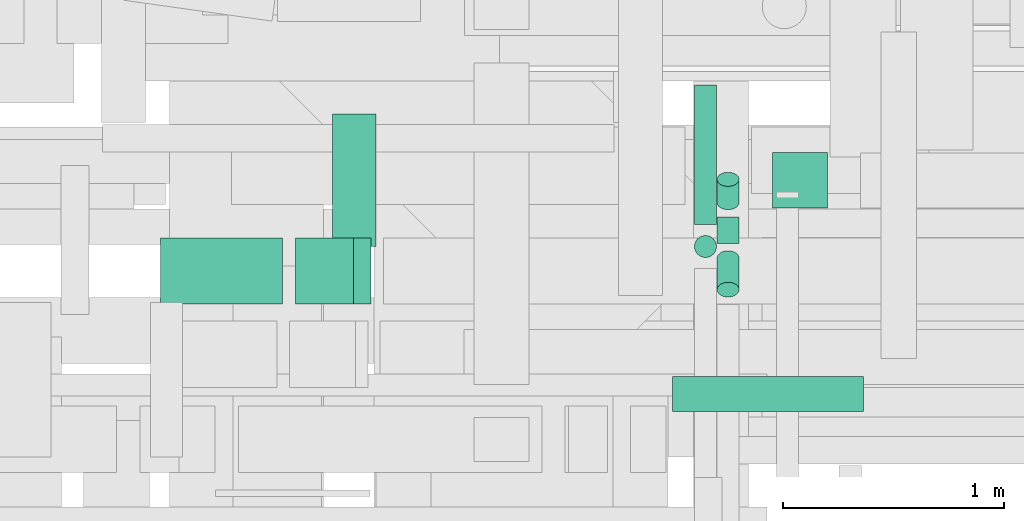
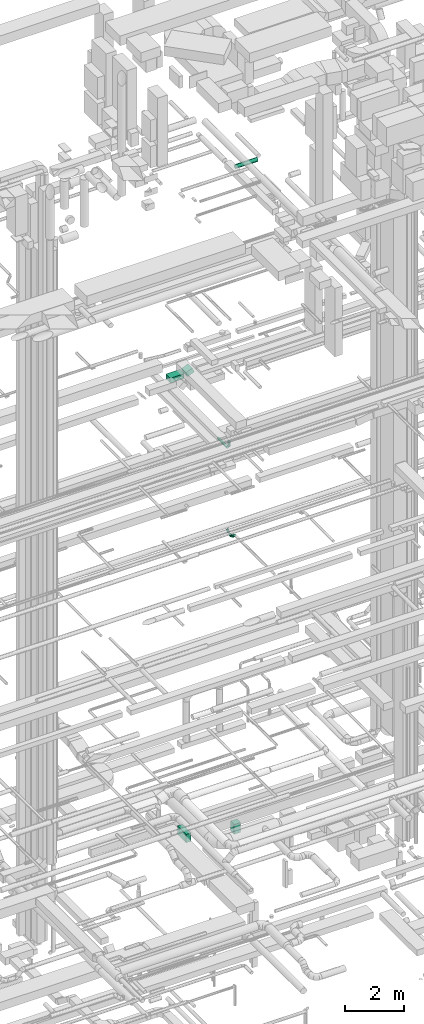
# One storey, part 174 of 337: 10 flow segments.
"""IFC2X3 building model written with IfcOpenShell, lengths in millimetres."""

from ifc_helpers import new_model, entity, si_unit, converted_unit, derived_unit, direction, frame, frame_2d, origin, origin_2d_with_axis, place, context, subcontext, project, spatial, rectangle, circle, extrude, type_object, element, save


model = new_model("IFC2X3")

# Units and contexts
model_context = context("Model", 3, precision=0.01, world=origin(), true_north=direction((6.12303176911189e-17, 1.0)))
body_context = subcontext(model_context, "Body", "Model", "MODEL_VIEW")
ifc_project = project(units=[si_unit("LENGTHUNIT", "METRE", prefix="MILLI"), si_unit("AREAUNIT", "SQUARE_METRE"), si_unit("VOLUMEUNIT", "CUBIC_METRE"), converted_unit("PLANEANGLEUNIT", "DEGREE", entity("IfcRatioMeasure", 0.0174532925199433), si_unit("PLANEANGLEUNIT", "RADIAN"), dimensions=[0, 0, 0, 0, 0, 0, 0]), si_unit("MASSUNIT", "GRAM", prefix="KILO"), derived_unit("MASSDENSITYUNIT", [(si_unit("MASSUNIT", "GRAM", prefix="KILO"), 1), (si_unit("LENGTHUNIT", "METRE"), -3)]), derived_unit("MOMENTOFINERTIAUNIT", [(si_unit("LENGTHUNIT", "METRE"), 4)]), si_unit("TIMEUNIT", "SECOND"), si_unit("FREQUENCYUNIT", "HERTZ"), si_unit("THERMODYNAMICTEMPERATUREUNIT", "DEGREE_CELSIUS"), derived_unit("THERMALTRANSMITTANCEUNIT", [(si_unit("MASSUNIT", "GRAM", prefix="KILO"), 1), (si_unit("THERMODYNAMICTEMPERATUREUNIT", "KELVIN"), -1), (si_unit("TIMEUNIT", "SECOND"), -3)]), derived_unit("VOLUMETRICFLOWRATEUNIT", [(si_unit("LENGTHUNIT", "METRE"), 3), (si_unit("TIMEUNIT", "SECOND"), -1)]), derived_unit("MASSFLOWRATEUNIT", [(si_unit("MASSUNIT", "GRAM", prefix="KILO"), 1), (si_unit("TIMEUNIT", "SECOND"), -1)]), derived_unit("ROTATIONALFREQUENCYUNIT", [(si_unit("TIMEUNIT", "SECOND"), -1)]), si_unit("ELECTRICCURRENTUNIT", "AMPERE"), si_unit("ELECTRICVOLTAGEUNIT", "VOLT"), si_unit("POWERUNIT", "WATT"), si_unit("FORCEUNIT", "NEWTON", prefix="KILO"), si_unit("ILLUMINANCEUNIT", "LUX"), si_unit("LUMINOUSFLUXUNIT", "LUMEN"), si_unit("LUMINOUSINTENSITYUNIT", "CANDELA"), derived_unit("USERDEFINED", [(si_unit("MASSUNIT", "GRAM", prefix="KILO"), -1), (si_unit("LENGTHUNIT", "METRE"), -2), (si_unit("TIMEUNIT", "SECOND"), 3), (si_unit("LUMINOUSFLUXUNIT", "LUMEN"), 1)]), derived_unit("LINEARVELOCITYUNIT", [(si_unit("LENGTHUNIT", "METRE"), 1), (si_unit("TIMEUNIT", "SECOND"), -1)]), si_unit("PRESSUREUNIT", "PASCAL"), derived_unit("USERDEFINED", [(si_unit("LENGTHUNIT", "METRE"), -2), (si_unit("MASSUNIT", "GRAM", prefix="KILO"), 1), (si_unit("TIMEUNIT", "SECOND"), -2)]), derived_unit("LINEARFORCEUNIT", [(si_unit("MASSUNIT", "GRAM", prefix="KILO"), 1), (si_unit("LENGTHUNIT", "METRE"), 1), (si_unit("TIMEUNIT", "SECOND"), -2), (si_unit("LENGTHUNIT", "METRE"), -1)]), derived_unit("PLANARFORCEUNIT", [(si_unit("MASSUNIT", "GRAM", prefix="KILO"), 1), (si_unit("LENGTHUNIT", "METRE"), 1), (si_unit("TIMEUNIT", "SECOND"), -2), (si_unit("LENGTHUNIT", "METRE"), -2)])], contexts=[model_context])

# Site, building, storey
site_placement = place(None, origin())
site = spatial("IfcSite", under=ifc_project, at=site_placement, CompositionType="ELEMENT")
building_placement = place(site_placement, origin())
building = spatial("IfcBuilding", under=site, at=building_placement, CompositionType="ELEMENT")
storey_placement = place(building_placement, origin())
storey = spatial("IfcBuildingStorey", under=building, at=storey_placement, CompositionType="ELEMENT", Elevation=0.0)

# Flow segments
duct_segment_type_1 = type_object("IfcDuctSegmentType", PredefinedType="NOTDEFINED")
flow_segment_1_placement = place(storey_placement, frame((38699.17, 15049.1, -875.0)))
element("IfcFlowSegment", 1, at=flow_segment_1_placement, inside=storey, type_object=duct_segment_type_1, context=body_context, shape_type="SweptSolid", body=[
    extrude(rectangle(XDim=196.431086282812, YDim=600.0, at=origin_2d_with_axis()), frame((98.22, 300.0, 0.0)), (0.0, 0.0, 1.0), 350.0),
])
flow_segment_2_placement = place(storey_placement, frame((40693.26, 15224.1, -1325.0)))
element("IfcFlowSegment", 2, at=flow_segment_2_placement, inside=storey, type_object=duct_segment_type_1, context=body_context, shape_type="SweptSolid", body=[
    extrude(rectangle(XDim=249.999999999999, YDim=250.000000000004, at=origin_2d_with_axis()), frame((125.0, 125.0, 0.0), z_axis=(0.0, 0.0, 1.0), x_axis=(0.0, -1.0, 0.0)), (0.0, 0.0, 1.0), 404.999974999966),
])
flow_segment_3_placement = place(storey_placement, frame((37920.11, 14788.36, 18700.0)))
element("IfcFlowSegment", 3, at=flow_segment_3_placement, inside=storey, type_object=duct_segment_type_1, context=body_context, shape_type="SweptSolid", body=[
    extrude(rectangle(XDim=553.10260709383, YDim=299.999999999999, at=origin_2d_with_axis()), frame((276.55, 150.0, 0.0), z_axis=(0.0, 0.0, 1.0), x_axis=(-1.0, 0.0, 0.0)), (0.0, 0.0, 1.0), 200.000000000002),
])
flow_segment_4_placement = place(storey_placement, frame((38531.3, 14788.36, 18727.31)))
element("IfcFlowSegment", 4, at=flow_segment_4_placement, inside=storey, type_object=duct_segment_type_1, context=body_context, shape_type="SweptSolid", body=[
    extrude(rectangle(XDim=200.000000000001, YDim=286.583755738021, at=frame_2d((0.0, 0.0), x_axis=(0.0, 1.0))), frame((170.84, 0.0, 147.69), z_axis=(0.0, 1.0, 0.0), x_axis=(-0.921968138776223, 0.0, -0.387265737035318)), (0.0, 0.0, 1.0), 300.000000000003),
])
duct_segment_type_2 = type_object("IfcDuctSegmentType", PredefinedType="NOTDEFINED")
flow_segment_5_placement = place(storey_placement, frame((40440.83, 15063.22, 11218.4)))
element("IfcFlowSegment", 5, at=flow_segment_5_placement, inside=storey, type_object=duct_segment_type_2, context=body_context, shape_type="SweptSolid", body=[
    extrude(circle(Radius=50.0, at=origin_2d_with_axis()), frame((51.6, 0.0, 51.6), z_axis=(0.0, 1.0, 0.0), x_axis=(-1.0, 0.0, 0.0)), (0.0, 0.0, 1.0), 120.666172473699),
])
flow_segment_6_placement = place(storey_placement, frame((40440.83, 15214.42, 11253.49)))
element("IfcFlowSegment", 6, at=flow_segment_6_placement, inside=storey, type_object=duct_segment_type_2, context=body_context, shape_type="SweptSolid", body=[
    extrude(circle(Radius=50.0, at=origin_2d_with_axis()), frame((51.6, 33.73, 39.9), z_axis=(0.0, 0.766125074379478, 0.64269150485053), x_axis=(1.0, 0.0, 0.0)), (0.0, 0.0, 1.0), 137.716940563638),
])
flow_segment_7_placement = place(storey_placement, frame((40440.83, 14818.33, 11256.91)))
element("IfcFlowSegment", 7, at=flow_segment_7_placement, inside=storey, type_object=duct_segment_type_2, context=body_context, shape_type="SweptSolid", body=[
    extrude(circle(Radius=50.0, at=origin_2d_with_axis()), frame((51.6, 178.0, 38.76), z_axis=(0.0, -0.743294146247178, 0.668964731622437), x_axis=(1.0, 0.0, 0.0)), (0.0, 0.0, 1.0), 192.325279895408),
])
flow_segment_8_placement = place(storey_placement, frame((40338.44, 15149.0, 14898.4)))
element("IfcFlowSegment", 8, at=flow_segment_8_placement, inside=storey, type_object=duct_segment_type_2, context=body_context, shape_type="SweptSolid", body=[
    extrude(circle(Radius=50.0, at=origin_2d_with_axis()), frame((51.6, 0.0, 51.6), z_axis=(0.0, 1.0, 0.0), x_axis=(-1.0, 0.0, 0.0)), (0.0, 0.0, 1.0), 631.000000000032),
])
flow_segment_9_placement = place(storey_placement, frame((40338.44, 14997.41, 15050.0)))
element("IfcFlowSegment", 9, at=flow_segment_9_placement, inside=storey, type_object=duct_segment_type_2, context=body_context, shape_type="SweptSolid", body=[
    extrude(circle(Radius=50.0, at=origin_2d_with_axis()), frame((51.6, 51.6, 0.0)), (0.0, 0.0, 1.0), 199.999998319795),
])
flow_segment_10_placement = place(storey_placement, frame((40240.11, 14299.27, 27068.4)))
element("IfcFlowSegment", 10, at=flow_segment_10_placement, inside=storey, type_object=duct_segment_type_2, context=body_context, shape_type="SweptSolid", body=[
    extrude(circle(Radius=80.0, at=origin_2d_with_axis()), frame((0.0, 81.6, 81.6), z_axis=(1.0, 0.0, 0.0), x_axis=(0.0, 1.0, 0.0)), (0.0, 0.0, 1.0), 865.849999999894),
])

save(model, "model.ifc")
